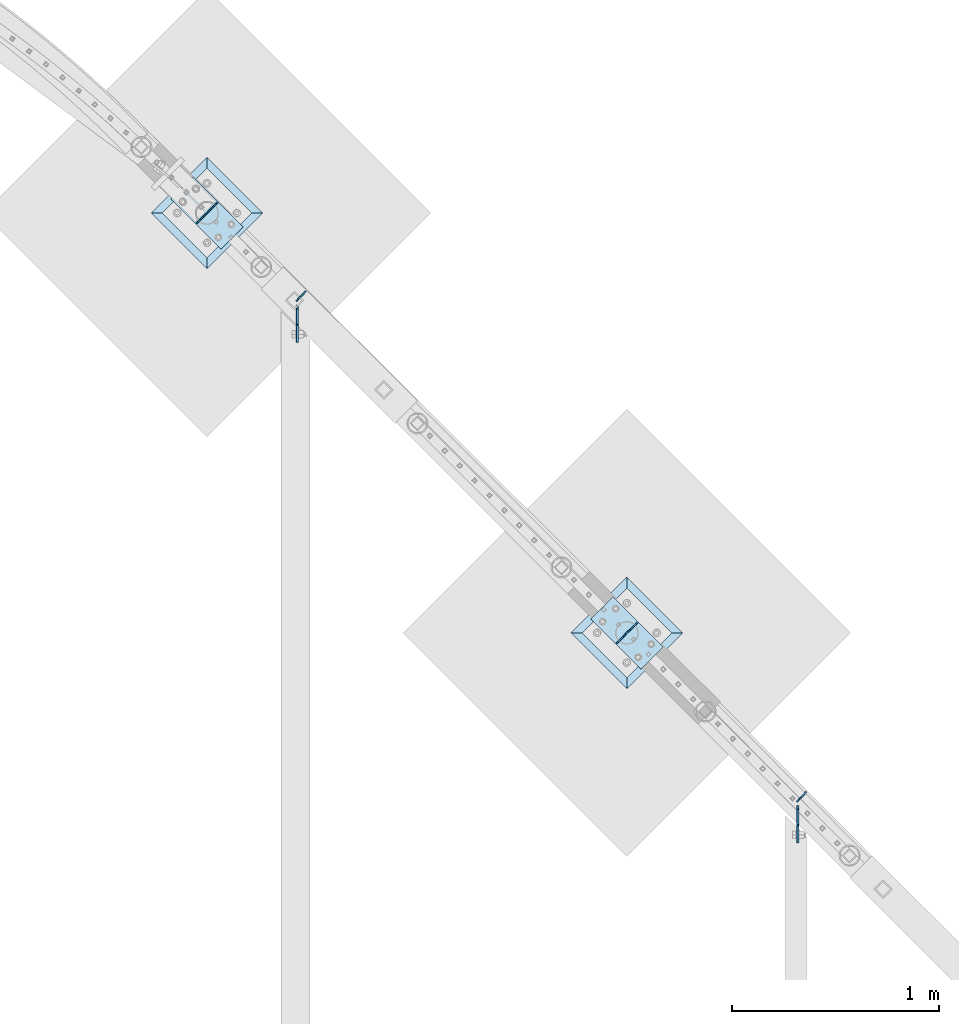
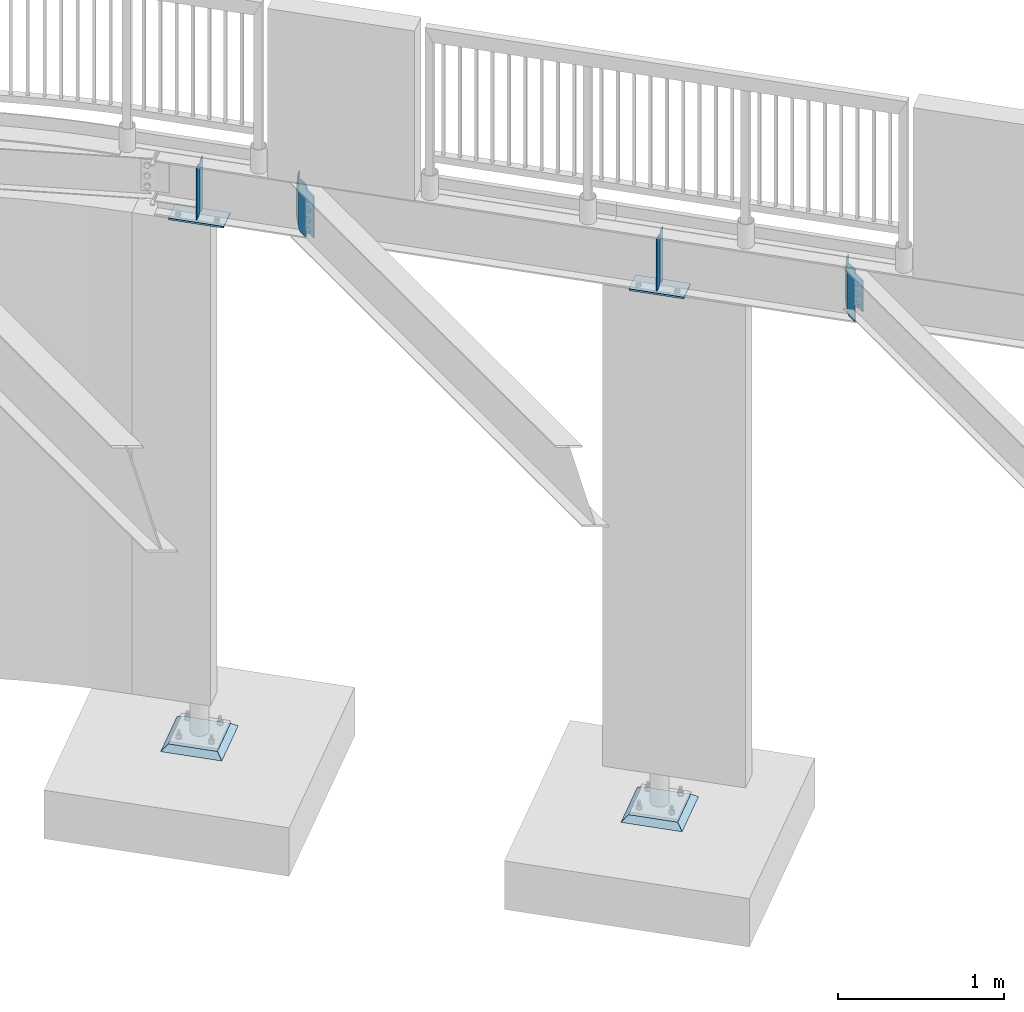
# One storey, part 872 of 975: 12 plates.
"""IFC2X3 building model written with IfcOpenShell, lengths in millimetres."""

from ifc_helpers import new_model, si_unit, frame, origin_with_axes, place, context, subcontext, project, spatial, faceted_brep, material, type_object, element, save


model = new_model("IFC2X3")

# Units and contexts
model_context = context("Model", 3, precision=1e-05, world=origin_with_axes())
body_context = subcontext(model_context, "Body", "Model", "MODEL_VIEW")
ifc_project = project(units=[si_unit("LENGTHUNIT", "METRE", prefix="MILLI"), si_unit("AREAUNIT", "SQUARE_METRE"), si_unit("VOLUMEUNIT", "CUBIC_METRE"), si_unit("MASSUNIT", "GRAM", prefix="KILO"), si_unit("TIMEUNIT", "SECOND"), si_unit("PLANEANGLEUNIT", "RADIAN"), si_unit("SOLIDANGLEUNIT", "STERADIAN"), si_unit("THERMODYNAMICTEMPERATUREUNIT", "DEGREE_CELSIUS"), si_unit("LUMINOUSINTENSITYUNIT", "LUMEN")], contexts=[model_context])

# Site, building, storey
site_placement = place(None, origin_with_axes())
site = spatial("IfcSite", under=ifc_project, at=site_placement, CompositionType="ELEMENT")
building_placement = place(site_placement, origin_with_axes())
building = spatial("IfcBuilding", under=site, at=building_placement, Name="Undefined", CompositionType="ELEMENT")
storey_placement = place(building_placement, origin_with_axes())
storey = spatial("IfcBuildingStorey", under=building, at=storey_placement, Name="Undefined", CompositionType="ELEMENT", Elevation=0.0)

# Plates
ifc_material_1 = material(Name="STEEL/A36")
plate_type_1 = type_object("IfcPlateType", PredefinedType="NOTDEFINED")
plate_1_placement = place(storey_placement, frame((23579.1374999562, 25046.2598719914, 3562.35000000001), z_axis=(0.0, -0.707106781186557, 0.707106781186538), x_axis=(0.0, -0.707106781186538, -0.707106781186557)))
element("IfcPlate", 1, at=plate_1_placement, inside=storey, type_object=plate_type_1, material=ifc_material_1, Name="PLATE", context=body_context, shape_type="Brep", body=[
    faceted_brep([(0.0, -4.76250000000073, 0.0), (-244.711975097704, -4.76250000000073, 244.711975097691), (-244.711975097704, 4.76250000000073, 244.711975097691), (0.0, 4.76250000000073, 0.0), (-244.711975097704, -4.76250000000073, 269.40768432621), (-244.711975097704, 4.76250000000073, 269.40768432621), (-193.752426147668, -4.76250000000073, 320.367248535043), (-193.752426147668, 4.76250000000073, 320.367248535043), (-183.649644887624, -4.76250000000073, 310.264451118641), (-183.649644887624, 4.76250000000073, 310.264451118641), (-179.529467921275, -4.76250000000073, 307.511432805499), (-179.529467921275, 4.76250000000073, 307.511432805499), (-174.669386031892, -4.76250000000073, 306.544700114962), (-174.669386031892, 4.76250000000073, 306.544700114962), (-169.809303486189, -4.76250000000073, 307.511429505943), (-169.809303486189, 4.76250000000073, 307.511429505943), (-165.689124650806, -4.76250000000073, 310.264445021854), (-165.689124650806, 4.76250000000073, 310.264445021854), (-111.455444336298, -4.76250000000073, 364.498138427469), (-111.455444336298, 4.76250000000073, 364.498138427469), (50.1891670223922, -4.76250000000073, 202.853515624702), (50.1891670223922, 4.76250000000073, 202.853515624702), (-4.04451522541058, -4.76250000000073, 148.619843195227), (-4.04451522541058, 4.76250000000073, 148.619843195227), (-6.79752958268364, -4.76250000000073, 144.499666773851), (-6.79752958268364, 4.76250000000073, 144.499666773851), (-7.76425986134564, -4.76250000000073, 139.639587107533), (-7.76425986134564, 4.76250000000073, 139.639587107533), (-6.79753012713263, -4.76250000000073, 134.779507332911), (-6.79753012713263, 4.76250000000073, 134.779507332911), (-4.04451623142086, -4.76250000000073, 130.659330603117), (-4.04451623142086, 4.76250000000073, 130.659330603117), (75.6552581785581, -4.76250000000073, 50.9595527647471), (75.6552581785581, 4.76250000000073, 50.9595527647471), (24.6957035064406, -4.76250000000073, -6.3664629124105e-11), (24.6957035064406, 4.76250000000073, -6.3664629124105e-11)], [[[0, 1, 2, 3]], [[1, 4, 5, 2]], [[4, 6, 7, 5]], [[6, 8, 9, 7]], [[8, 10, 11, 9]], [[10, 12, 13, 11]], [[12, 14, 15, 13]], [[14, 16, 17, 15]], [[16, 18, 19, 17]], [[18, 20, 21, 19]], [[20, 22, 23, 21]], [[22, 24, 25, 23]], [[24, 26, 27, 25]], [[26, 28, 29, 27]], [[28, 30, 31, 29]], [[30, 32, 33, 31]], [[32, 34, 35, 33]], [[34, 0, 3, 35]], [[5, 7, 9, 11, 13, 15, 17, 19, 21, 23, 25, 27, 29, 31, 33, 35, 3, 2]], [[34, 32, 30, 28, 26, 24, 22, 20, 18, 16, 14, 12, 10, 8, 6, 4, 1, 0]]]),
])
plate_2_placement = place(storey_placement, frame((21166.137499991, 27459.2598719508, 3562.35000000001), z_axis=(0.0, -0.707106781186557, 0.707106781186538), x_axis=(0.0, -0.707106781186538, -0.707106781186557)))
element("IfcPlate", 2, at=plate_2_placement, inside=storey, type_object=plate_type_1, material=ifc_material_1, Name="PLATE", context=body_context, shape_type="Brep", body=[
    faceted_brep([(0.0, -4.76250000000073, 0.0), (-244.711975097704, -4.76250000000073, 244.711975097691), (-244.711975097704, 4.76250000000073, 244.711975097691), (0.0, 4.76250000000073, 0.0), (-244.711975097704, -4.76250000000073, 269.40768432621), (-244.711975097704, 4.76250000000073, 269.40768432621), (-193.752426147668, -4.76250000000073, 320.367248535043), (-193.752426147668, 4.76250000000073, 320.367248535043), (-183.649644887624, -4.76250000000073, 310.264451118641), (-183.649644887624, 4.76250000000073, 310.264451118641), (-179.529467921275, -4.76250000000073, 307.511432805499), (-179.529467921275, 4.76250000000073, 307.511432805499), (-174.669386031892, -4.76250000000073, 306.544700114962), (-174.669386031892, 4.76250000000073, 306.544700114962), (-169.809303486189, -4.76250000000073, 307.511429505943), (-169.809303486189, 4.76250000000073, 307.511429505943), (-165.689124650806, -4.76250000000073, 310.264445021854), (-165.689124650806, 4.76250000000073, 310.264445021854), (-111.455444336298, -4.76250000000073, 364.498138427469), (-111.455444336298, 4.76250000000073, 364.498138427469), (104.070701598808, -4.76250000000073, 148.971984862987), (104.070701598808, 4.76250000000073, 148.971984862987), (49.8370211414658, -4.76250000000073, 94.7382978600908), (49.8370211414658, 4.76250000000073, 94.7382978600908), (47.0840074963562, -4.76250000000073, 90.6181212420452), (47.0840074963562, 4.76250000000073, 90.6181212420452), (46.1172778603395, -4.76250000000073, 85.7580416845776), (46.1172778603395, 4.76250000000073, 85.7580416845776), (47.0840080560411, -4.76250000000073, 80.8979622384322), (47.0840080560411, 4.76250000000073, 80.8979622384322), (49.8370221756268, -4.76250000000073, 76.7777859374146), (49.8370221756268, 4.76250000000073, 76.7777859374146), (75.6552581785581, -4.76250000000073, 50.9595527647471), (75.6552581785581, 4.76250000000073, 50.9595527647471), (24.6957035064406, -4.76250000000073, -6.3664629124105e-11), (24.6957035064406, 4.76250000000073, -6.3664629124105e-11)], [[[0, 1, 2, 3]], [[1, 4, 5, 2]], [[4, 6, 7, 5]], [[6, 8, 9, 7]], [[8, 10, 11, 9]], [[10, 12, 13, 11]], [[12, 14, 15, 13]], [[14, 16, 17, 15]], [[16, 18, 19, 17]], [[18, 20, 21, 19]], [[20, 22, 23, 21]], [[22, 24, 25, 23]], [[24, 26, 27, 25]], [[26, 28, 29, 27]], [[28, 30, 31, 29]], [[30, 32, 33, 31]], [[32, 34, 35, 33]], [[34, 0, 3, 35]], [[5, 7, 9, 11, 13, 15, 17, 19, 21, 23, 25, 27, 29, 31, 33, 35, 3, 2]], [[34, 32, 30, 28, 26, 24, 22, 20, 18, 16, 14, 12, 10, 8, 6, 4, 1, 0]]]),
])
plate_type_2 = type_object("IfcPlateType", PredefinedType="NOTDEFINED")
for number, where, z_axis, x_axis, name in (
    (3, (23620.5914086658, 25112.8414086658, 3544.88749999999), (0.0, 0.0, 1.0), (-0.707106781186548, -0.707106781186548, 0.0), "PLATE"),
    (4, (21207.5914086658, 27525.8414086657, 3544.88749999998), (0.0, 0.0, 1.0), (-0.707106781186548, -0.707106781186548, 0.0), "PLATE"),
):
    element("IfcPlate", number, at=place(storey_placement, frame(where, z_axis=z_axis, x_axis=x_axis)), inside=storey, type_object=plate_type_2, material=ifc_material_1, Name=name, context=body_context, shape_type="Brep", body=[
        faceted_brep([(0.0, -3.17499999999927, 0.0), (1.83717929758132e-10, -3.17499999972279, 381.000000000335), (1.90993887372315e-10, 3.17500000029031, 381.000000000333), (0.0, 3.17499999999927, 0.0), (34.9250030519688, -3.17499999970096, 381.000000000334), (34.9250030519761, 3.17500000031214, 381.000000000333), (66.675003051947, -3.17499999974825, 288.92500305201), (66.6750030519561, 3.17500000026121, 288.92500305201), (66.6750030518542, -3.17499999989377, 92.0749969483222), (66.6750030518597, 3.17500000011569, 92.0749969483222), (34.9250030517815, -3.17499999998472, -1.81898940354586e-12), (34.9250030517906, 3.17500000002838, -1.81898940354586e-12)], [[[0, 1, 2, 3]], [[1, 4, 5, 2]], [[4, 6, 7, 5]], [[6, 8, 9, 7]], [[8, 10, 11, 9]], [[10, 0, 3, 11]], [[5, 7, 9, 11, 3, 2]], [[10, 8, 6, 4, 1, 0]]]),
    ])
for number, where, z_axis, x_axis, name in (
    (5, (20681.7710913342, 27854.0960913342, 3925.8875), (0.0, 0.0, -1.0), (0.707106781186548, 0.707106781186548, 0.0), "PLATE"),
    (6, (22705.8335913342, 25830.0335913342, 3925.88749999999), (0.0, 0.0, -1.0), (0.707106781186548, 0.707106781186548, 0.0), "PLATE"),
    (7, (22804.6164086655, 25928.8164086655, 3925.88749999999), (0.0, 0.0, -1.0), (-0.707106781186548, -0.707106781186548, 0.0), "PLATE"),
    (8, (20780.5539086655, 27952.8789086655, 3925.8875), (0.0, 0.0, -1.0), (-0.707106781186548, -0.707106781186548, 0.0), "PLATE"),
):
    element("IfcPlate", number, at=place(storey_placement, frame(where, z_axis=z_axis, x_axis=x_axis)), inside=storey, type_object=plate_type_2, material=ifc_material_1, Name=name, context=body_context, shape_type="Brep", body=[
        faceted_brep([(0.0, -3.17499999999927, 0.0), (1.83717929758132e-10, -3.17499999972279, 381.000000000335), (1.90993887372315e-10, 3.17500000029031, 381.000000000333), (0.0, 3.17499999999927, 0.0), (47.6250038151447, -3.17500000000291, 380.9999999998), (47.6250038151411, 3.17500000000109, 380.999999999805), (66.6750030521871, -3.17500000001564, 361.95000076275), (66.6750030521871, 3.17499999998654, 361.950000762756), (66.6750030518015, -3.17500000004475, 19.0499992370478), (66.6750030517978, 3.17499999995925, 19.0499992370533), (47.625, -3.17499999999927, 0.0), (47.625, 3.17499999999927, 0.0)], [[[0, 1, 2, 3]], [[1, 4, 5, 2]], [[4, 6, 7, 5]], [[6, 8, 9, 7]], [[8, 10, 11, 9]], [[10, 0, 3, 11]], [[5, 7, 9, 11, 3, 2]], [[10, 8, 6, 4, 1, 0]]]),
    ])
plate_type_3 = type_object("IfcPlateType", PredefinedType="NOTDEFINED")
for number, where, z_axis, x_axis, name in (
    (9, (22930.3399943604, 25812.0730790921, 3527.425), (-0.707106781186601, 0.707106781186494, 2.36468622460961e-14), (-0.707106781186548, -0.707106781186548, 0.0), "PLATE"),
    (10, (20906.2774943604, 27836.1355790921, 3527.425), (-0.707106781186601, 0.707106781186494, 2.36468622460961e-14), (-0.707106781186548, -0.707106781186548, 0.0), "PLATE"),
):
    element("IfcPlate", number, at=place(storey_placement, frame(where, z_axis=z_axis, x_axis=x_axis)), inside=storey, type_object=plate_type_3, material=ifc_material_1, Name=name, context=body_context, shape_type="Brep", body=[
        faceted_brep([(0.0, -6.34999999998763, -3.63797880709171e-12), (-4.32919478043914e-10, -6.34999999999991, 342.899993895661), (-4.32919478043914e-10, 6.34999999999991, 342.899993895661), (0.0, 6.34999999999491, 5.45696821063757e-12), (152.399993896484, -6.34999999995307, 342.899993896505), (152.399993896484, 6.35000000004766, 342.899993896504), (152.399993896484, -6.34999999999854, 9.09494701772928e-13), (152.399993896484, 6.35000000000127, 0.0)], [[[0, 1, 2, 3]], [[1, 4, 5, 2]], [[4, 6, 7, 5]], [[6, 0, 3, 7]], [[5, 7, 3, 2]], [[6, 4, 1, 0]]]),
    ])
ifc_material_2 = material(Name="CONCRETE/GROUT")
plate_type_4 = type_object("IfcPlateType", PredefinedType="NOTDEFINED")
for number, where, z_axis, x_axis, name in (
    (11, (23024.6326836314, 25879.4250000001, -285.749999999999), (-0.707106781186548, -0.707106781186548, 0.0), (-0.707106781186601, 0.707106781186494, 2.36468622460961e-14), "GROUT"),
    (12, (21000.5701836314, 27903.4875000001, -285.749999999999), (-0.707106781186548, -0.707106781186548, 0.0), (-0.707106781186601, 0.707106781186494, 2.36468622460961e-14), "GROUT"),
):
    element("IfcPlate", number, at=place(storey_placement, frame(where, z_axis=z_axis, x_axis=x_axis)), inside=storey, type_object=plate_type_4, material=ifc_material_2, Name=name, context=body_context, shape_type="Brep", body=[
        faceted_brep([(38.1000000096292, -19.05, 342.899999985777), (0.0, 19.05, 381.0), (2.63382389675826e-07, 19.0500000000138, 0.0), (38.1000000092372, -19.05, 38.1000000116328), (342.899999988684, -19.05, 38.1000000120257), (381.0, 19.05, 0.0), (381.0, 19.05, 381.0), (342.899999989076, -19.05, 342.89999998617)], [[[0, 1, 2, 3]], [[4, 5, 6, 7]], [[4, 7, 0, 3]], [[5, 4, 3, 2]], [[6, 5, 2, 1]], [[7, 6, 1, 0]]]),
    ])

save(model, "model.ifc")
